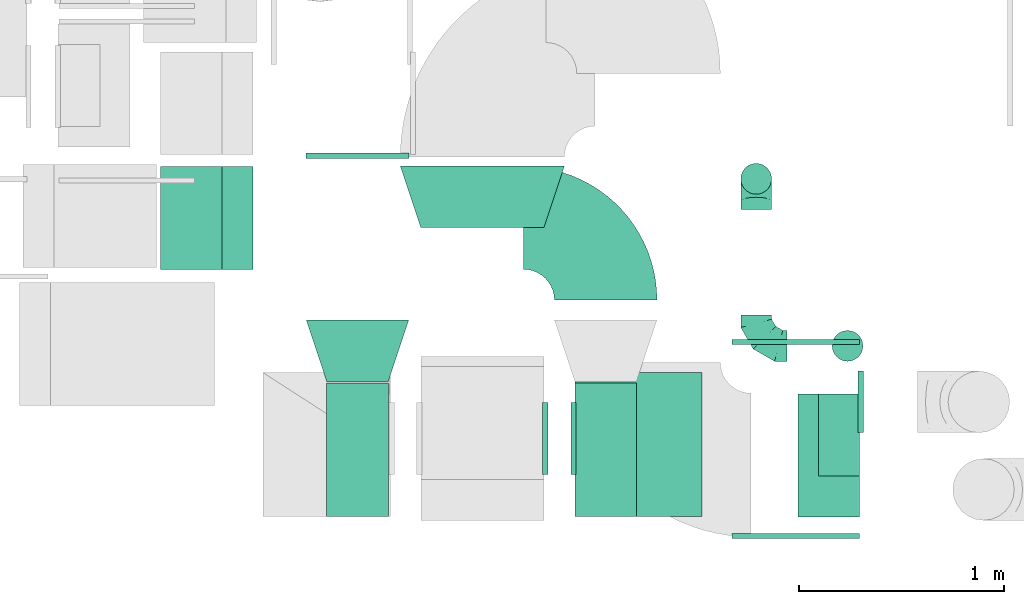
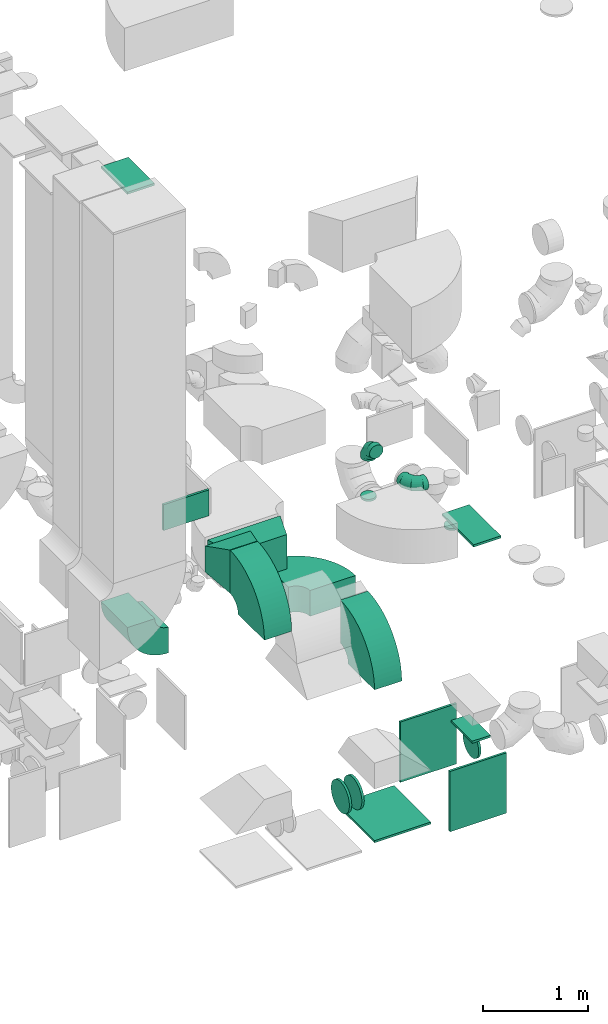
# One storey, part 20 of 59: 20 flow fittings.
"""IFC2X3 building model written with IfcOpenShell, lengths in millimetres."""

from ifc_helpers import new_model, entity, si_unit, converted_unit, derived_unit, direction, frame, frame_2d, origin, origin_2d_with_axis, place, context, subcontext, project, spatial, polyline, circle_curve, parameter, trimmed, segment, composite_curve, rectangle, circle, outline, extrude, faceted_brep, source, transform, mapped, material, type_object, type_shapes, element, save


model = new_model("IFC2X3")

# Units and contexts
model_context = context("Model", 3, precision=0.01, world=origin(), true_north=direction((6.12303176911189e-17, 1.0)))
body_context = subcontext(model_context, "Body", "Model", "MODEL_VIEW")
ifc_project = project(units=[si_unit("LENGTHUNIT", "METRE", prefix="MILLI"), si_unit("AREAUNIT", "SQUARE_METRE"), si_unit("VOLUMEUNIT", "CUBIC_METRE"), converted_unit("PLANEANGLEUNIT", "DEGREE", entity("IfcRatioMeasure", 0.0174532925199433), si_unit("PLANEANGLEUNIT", "RADIAN"), dimensions=[0, 0, 0, 0, 0, 0, 0]), si_unit("MASSUNIT", "GRAM", prefix="KILO"), derived_unit("MASSDENSITYUNIT", [(si_unit("MASSUNIT", "GRAM", prefix="KILO"), 1), (si_unit("LENGTHUNIT", "METRE"), -3)]), derived_unit("MOMENTOFINERTIAUNIT", [(si_unit("LENGTHUNIT", "METRE"), 4)]), si_unit("TIMEUNIT", "SECOND"), si_unit("FREQUENCYUNIT", "HERTZ"), si_unit("THERMODYNAMICTEMPERATUREUNIT", "DEGREE_CELSIUS"), derived_unit("THERMALTRANSMITTANCEUNIT", [(si_unit("MASSUNIT", "GRAM", prefix="KILO"), 1), (si_unit("THERMODYNAMICTEMPERATUREUNIT", "KELVIN"), -1), (si_unit("TIMEUNIT", "SECOND"), -3)]), derived_unit("VOLUMETRICFLOWRATEUNIT", [(si_unit("LENGTHUNIT", "METRE"), 3), (si_unit("TIMEUNIT", "SECOND"), -1)]), derived_unit("MASSFLOWRATEUNIT", [(si_unit("MASSUNIT", "GRAM", prefix="KILO"), 1), (si_unit("TIMEUNIT", "SECOND"), -1)]), derived_unit("ROTATIONALFREQUENCYUNIT", [(si_unit("TIMEUNIT", "SECOND"), -1)]), si_unit("ELECTRICCURRENTUNIT", "AMPERE"), si_unit("ELECTRICVOLTAGEUNIT", "VOLT"), si_unit("POWERUNIT", "WATT"), si_unit("FORCEUNIT", "NEWTON", prefix="KILO"), si_unit("ILLUMINANCEUNIT", "LUX"), si_unit("LUMINOUSFLUXUNIT", "LUMEN"), si_unit("LUMINOUSINTENSITYUNIT", "CANDELA"), derived_unit("USERDEFINED", [(si_unit("MASSUNIT", "GRAM", prefix="KILO"), -1), (si_unit("LENGTHUNIT", "METRE"), -2), (si_unit("TIMEUNIT", "SECOND"), 3), (si_unit("LUMINOUSFLUXUNIT", "LUMEN"), 1)]), derived_unit("LINEARVELOCITYUNIT", [(si_unit("LENGTHUNIT", "METRE"), 1), (si_unit("TIMEUNIT", "SECOND"), -1)]), si_unit("PRESSUREUNIT", "PASCAL"), derived_unit("USERDEFINED", [(si_unit("LENGTHUNIT", "METRE"), -2), (si_unit("MASSUNIT", "GRAM", prefix="KILO"), 1), (si_unit("TIMEUNIT", "SECOND"), -2)]), derived_unit("LINEARFORCEUNIT", [(si_unit("MASSUNIT", "GRAM", prefix="KILO"), 1), (si_unit("LENGTHUNIT", "METRE"), 1), (si_unit("TIMEUNIT", "SECOND"), -2), (si_unit("LENGTHUNIT", "METRE"), -1)]), derived_unit("PLANARFORCEUNIT", [(si_unit("MASSUNIT", "GRAM", prefix="KILO"), 1), (si_unit("LENGTHUNIT", "METRE"), 1), (si_unit("TIMEUNIT", "SECOND"), -2), (si_unit("LENGTHUNIT", "METRE"), -2)])], contexts=[model_context])

# Site, building, storey
site_placement = place(None, origin())
site = spatial("IfcSite", under=ifc_project, at=site_placement, CompositionType="ELEMENT")
building_placement = place(site_placement, origin())
building = spatial("IfcBuilding", under=site, at=building_placement, CompositionType="ELEMENT")
storey_placement = place(building_placement, frame((0.0, 0.0, 28200.0)))
storey = spatial("IfcBuildingStorey", under=building, at=storey_placement, CompositionType="ELEMENT", Elevation=28200.0)

# Flow fittings
ifc_material = material()
duct_fitting_type_1 = type_object("IfcDuctFittingType", PredefinedType="NOTDEFINED", material=ifc_material)
shared_shape_1 = source(origin(), body_context, "Body", "SweptSolid", [
    extrude(rectangle(XDim=26.0960000000224, YDim=500.0, at=origin_2d_with_axis()), frame((6.95, 0.0, -150.0)), (0.0, 0.0, 1.0), 300.0),
])
type_shapes(duct_fitting_type_1, [shared_shape_1])
flow_fitting_1_placement = place(storey_placement, frame((49765.11, 9773.84, 3450.0), z_axis=(0.0, 0.0, -1.0), x_axis=(0.0, -1.0, 0.0)))
element("IfcFlowFitting", 1, at=flow_fitting_1_placement, inside=storey, type_object=duct_fitting_type_1, material=ifc_material, context=body_context, shape_type="MappedRepresentation", body=[
    mapped(shared_shape_1, transform((0.0, 0.0, 0.0), scale=1.0)),
])
duct_fitting_type_2 = type_object("IfcDuctFittingType", PredefinedType="NOTDEFINED", material=ifc_material)
shared_shape_2 = source(origin(), body_context, "Body", "SweptSolid", [
    extrude(rectangle(XDim=24.9999999999999, YDim=500.0, at=origin_2d_with_axis()), frame((12.5, 0.0, -150.0)), (0.0, 0.0, 1.0), 300.0),
])
type_shapes(duct_fitting_type_2, [shared_shape_2])
flow_fitting_2_placement = place(storey_placement, frame((48955.39, 9463.84, 7780.0), z_axis=(1.0, 0.0, 0.0), x_axis=(0.0, 0.0, 1.0)))
element("IfcFlowFitting", 2, at=flow_fitting_2_placement, inside=storey, type_object=duct_fitting_type_2, material=ifc_material, context=body_context, shape_type="MappedRepresentation", body=[
    mapped(shared_shape_2, transform((0.0, 0.0, 0.0), scale=1.0)),
])
duct_fitting_type_3 = type_object("IfcDuctFittingType", PredefinedType="NOTDEFINED", material=ifc_material)
shared_shape_3 = source(origin(), body_context, "Body", "SweptSolid", [
    extrude(rectangle(XDim=24.9999999999999, YDim=620.0, at=origin_2d_with_axis()), frame((12.5, 0.0, -350.0)), (0.0, 0.0, 1.0), 700.0),
])
type_shapes(duct_fitting_type_3, [shared_shape_3])
for number, where, z_axis, x_axis in (
    (3, (51134.61, 8360.0, 300.0), (0.0, 1.0, 0.0), (0.0, 0.0, -1.0)),
    (4, (51900.61, 7927.0, 550.0), (0.0, 0.0, 1.0), (0.0, -1.0, 0.0)),
    (5, (51900.61, 8847.0, 550.0), (0.0, 0.0, 1.0), (0.0, 1.0, 0.0)),
):
    element("IfcFlowFitting", number, at=place(storey_placement, frame(where, z_axis=z_axis, x_axis=x_axis)), inside=storey, type_object=duct_fitting_type_3, material=ifc_material, context=body_context, shape_type="MappedRepresentation", body=[
        mapped(shared_shape_3, transform((0.0, 0.0, 0.0), scale=1.0)),
    ])
duct_fitting_type_4 = type_object("IfcDuctFittingType", PredefinedType="NOTDEFINED", material=ifc_material)
shared_shape_4 = source(origin(), body_context, "Body", "SweptSolid", [
    extrude(rectangle(XDim=26.0960000000046, YDim=200.0, at=origin_2d_with_axis()), frame((6.95, 0.0, -200.0)), (0.0, 0.0, 1.0), 400.0),
])
type_shapes(duct_fitting_type_4, [shared_shape_4])
flow_fitting_3_placement = place(storey_placement, frame((52110.61, 8406.69, 900.0), z_axis=(0.0, -1.0, 0.0), x_axis=(0.0, 0.0, 1.0)))
element("IfcFlowFitting", 6, at=flow_fitting_3_placement, inside=storey, type_object=duct_fitting_type_4, material=ifc_material, context=body_context, shape_type="MappedRepresentation", body=[
    mapped(shared_shape_4, transform((0.0, 0.0, 0.0), scale=1.0)),
])
duct_fitting_type_5 = type_object("IfcDuctFittingType", PredefinedType="NOTDEFINED", material=ifc_material)
shared_shape_5 = source(origin(), body_context, "Body", "SweptSolid", [
    extrude(rectangle(XDim=26.0960000000048, YDim=300.0, at=origin_2d_with_axis()), frame((6.95, 0.0, -300.0)), (0.0, 0.0, 1.0), 600.0),
])
type_shapes(duct_fitting_type_5, [shared_shape_5])
flow_fitting_4_placement = place(storey_placement, frame((52060.61, 8306.69, 3350.0), z_axis=(0.0, 1.0, 0.0), x_axis=(0.0, 0.0, -1.0)))
element("IfcFlowFitting", 7, at=flow_fitting_4_placement, inside=storey, type_object=duct_fitting_type_5, material=ifc_material, context=body_context, shape_type="MappedRepresentation", body=[
    mapped(shared_shape_5, transform((0.0, 0.0, 0.0), scale=1.0)),
])
duct_fitting_type_6 = type_object("IfcDuctFittingType", PredefinedType="NOTDEFINED", material=ifc_material)
shared_shape_6 = source(origin(), body_context, "Body", "SweptSolid", [
    extrude(circle(Radius=74.9999999999995, at=origin_2d_with_axis()), frame((0.0, 0.0, 0.0), z_axis=(1.0, 0.0, 0.0), x_axis=(0.0, 1.0, 0.0)), (0.0, 0.0, 1.0), 25.0000000000018),
])
type_shapes(duct_fitting_type_6, [shared_shape_6])
for number, where, z_axis, x_axis in (
    (8, (51708.0, 9654.72, 3008.0), (0.0, -1.0, 0.0), (0.0, 0.0, -1.0)),
    (9, (52153.19, 8840.5, 3008.0), (0.0, -1.0, 0.0), (0.0, 0.0, -1.0)),
):
    element("IfcFlowFitting", number, at=place(storey_placement, frame(where, z_axis=z_axis, x_axis=x_axis)), inside=storey, type_object=duct_fitting_type_6, material=ifc_material, context=body_context, shape_type="MappedRepresentation", body=[
        mapped(shared_shape_6, transform((0.0, 0.0, 0.0), scale=1.0)),
    ])
duct_fitting_type_7 = type_object("IfcDuctFittingType", PredefinedType="NOTDEFINED", material=ifc_material)
shared_shape_7 = source(origin(), body_context, "Body", "SweptSolid", [
    extrude(outline(polyline([(-268.79, -332.04), (47.43, -332.04), (237.17, 237.17), (-15.81, 426.91), (-268.79, -332.04)])), frame((150.0, 0.0, -200.01), z_axis=(5.7818159732618e-05, 0.0, 1.0), x_axis=(0.948683296623388, 0.316227765541128, -5.48511224715197e-05)), (-5.48511224715197e-05, 1.82837074599458e-05, 1.0), 400.0),
])
type_shapes(duct_fitting_type_7, [shared_shape_7])
flow_fitting_5_placement = place(storey_placement, frame((50373.61, 9717.0, 2855.0), z_axis=(0.0, -4.00643741305655e-05, 1.0), x_axis=(1.85007582336496e-08, -1.0, -4.00643741305654e-05)))
element("IfcFlowFitting", 10, at=flow_fitting_5_placement, inside=storey, type_object=duct_fitting_type_7, material=ifc_material, context=body_context, shape_type="MappedRepresentation", body=[
    mapped(shared_shape_7, transform((0.0, 0.0, 0.0), scale=1.0)),
])
duct_fitting_type_8 = type_object("IfcDuctFittingType", PredefinedType="NOTDEFINED", material=ifc_material)
shared_shape_8 = source(origin(), body_context, "Body", "Brep", [
    faceted_brep([(300.0, -250.0, 150.0), (300.0, -250.0, -150.0), (300.0, 250.0, -150.0), (300.0, 250.0, 150.0), (0.0, -150.0, 250.0), (0.0, 150.0, 250.0), (0.0, 150.0, -250.0), (0.0, -150.0, -250.0)], [[[0, 1, 2, 3]], [[4, 5, 6, 7]], [[4, 7, 1, 0]], [[7, 6, 2, 1]], [[6, 5, 3, 2]], [[5, 4, 0, 3]]]),
])
type_shapes(duct_fitting_type_8, [shared_shape_8])
flow_fitting_6_placement = place(storey_placement, frame((49765.11, 8666.84, 3450.0), z_axis=(0.0, 0.0, 1.0), x_axis=(0.0, 1.0, 0.0)))
element("IfcFlowFitting", 11, at=flow_fitting_6_placement, inside=storey, type_object=duct_fitting_type_8, material=ifc_material, context=body_context, shape_type="MappedRepresentation", body=[
    mapped(shared_shape_8, transform((0.0, 0.0, 0.0), scale=1.0)),
])
duct_fitting_type_9 = type_object("IfcDuctFittingType", PredefinedType="NOTDEFINED", material=ifc_material)
shared_shape_9 = source(origin(), body_context, "Body", "Brep", [
    faceted_brep([(20.0, 38.82, -144.89), (20.0, 75.0, -129.9), (20.0, 106.07, -106.07), (20.0, 129.9, -75.0), (20.0, 144.89, -38.82), (20.0, 150.0, 0.0), (20.0, 144.89, 38.82), (20.0, 129.9, 75.0), (20.0, 106.07, 106.07), (20.0, 75.0, 129.9), (20.0, 38.82, 144.89), (20.0, 0.0, 150.0), (20.0, -38.82, 144.89), (20.0, -75.0, 129.9), (20.0, -106.07, 106.07), (20.0, -129.9, 75.0), (20.0, -144.89, 38.82), (20.0, -150.0, 0.0), (20.0, -144.89, -38.82), (20.0, -129.9, -75.0), (20.0, -106.07, -106.07), (20.0, -75.0, -129.9), (20.0, -38.82, -144.89), (20.0, 0.0, -150.0), (0.0, 0.0, 150.0), (0.0, 38.82, 144.89), (-6.1, 38.82, 144.89), (-6.1, 0.0, 150.0), (0.0, 75.0, 129.9), (-6.1, 75.0, 129.9), (0.0, 106.07, 106.07), (-6.1, 106.07, 106.07), (0.0, 129.9, 75.0), (0.0, 144.89, 38.82), (-6.1, 144.89, 38.82), (-6.1, 129.9, 75.0), (0.0, 150.0, 0.0), (-6.1, 150.0, 0.0), (0.0, 144.89, -38.82), (-6.1, 144.89, -38.82), (0.0, 129.9, -75.0), (-6.1, 129.9, -75.0), (0.0, 106.07, -106.07), (-6.1, 106.07, -106.07), (0.0, 75.0, -129.9), (0.0, 38.82, -144.89), (-6.1, 38.82, -144.89), (-6.1, 75.0, -129.9), (0.0, 0.0, -150.0), (-6.1, 0.0, -150.0), (0.0, -38.82, -144.89), (-6.1, -38.82, -144.89), (0.0, -75.0, -129.9), (-6.1, -75.0, -129.9), (0.0, -106.07, -106.07), (-6.1, -106.07, -106.07), (0.0, -129.9, -75.0), (0.0, -144.89, -38.82), (-6.1, -144.89, -38.82), (-6.1, -129.9, -75.0), (0.0, -150.0, 0.0), (-6.1, -150.0, 0.0), (0.0, -144.89, 38.82), (-6.1, -144.89, 38.82), (0.0, -129.9, 75.0), (-6.1, -129.9, 75.0), (0.0, -106.07, 106.07), (-6.1, -106.07, 106.07), (0.0, -75.0, 129.9), (0.0, -38.82, 144.89), (-6.1, -38.82, 144.89), (-6.1, -75.0, 129.9)], [[[0, 1, 2, 3, 4, 5, 6, 7, 8, 9, 10, 11, 12, 13, 14, 15, 16, 17, 18, 19, 20, 21, 22, 23]], [[24, 11, 10, 25, 26, 27]], [[25, 10, 9, 28, 29, 26]], [[28, 9, 8, 30, 31, 29]], [[32, 7, 6, 33, 34, 35]], [[33, 6, 5, 36, 37, 34]], [[30, 8, 7, 32, 35, 31]], [[36, 5, 4, 38, 39, 37]], [[38, 4, 3, 40, 41, 39]], [[40, 3, 2, 42, 43, 41]], [[44, 1, 0, 45, 46, 47]], [[45, 0, 23, 48, 49, 46]], [[42, 2, 1, 44, 47, 43]], [[48, 23, 22, 50, 51, 49]], [[50, 22, 21, 52, 53, 51]], [[52, 21, 20, 54, 55, 53]], [[56, 19, 18, 57, 58, 59]], [[57, 18, 17, 60, 61, 58]], [[54, 20, 19, 56, 59, 55]], [[60, 17, 16, 62, 63, 61]], [[62, 16, 15, 64, 65, 63]], [[64, 15, 14, 66, 67, 65]], [[68, 13, 12, 69, 70, 71]], [[69, 12, 11, 24, 27, 70]], [[66, 14, 13, 68, 71, 67]], [[49, 51, 53, 55, 59, 58, 61, 63, 65, 67, 71, 70, 27, 26, 29, 31, 35, 34, 37, 39, 41, 43, 47, 46]]]),
])
type_shapes(duct_fitting_type_9, [shared_shape_9])
flow_fitting_7_placement = place(storey_placement, frame((52210.61, 8567.36, 605.29), z_axis=(0.0, 0.0, -1.0), x_axis=(1.0, 0.0, 0.0)))
element("IfcFlowFitting", 12, at=flow_fitting_7_placement, inside=storey, type_object=duct_fitting_type_9, material=ifc_material, context=body_context, shape_type="MappedRepresentation", body=[
    mapped(shared_shape_9, transform((0.0, 0.0, 0.0), scale=1.0)),
])
duct_fitting_type_10 = type_object("IfcDuctFittingType", PredefinedType="NOTDEFINED", material=ifc_material)
shared_shape_10 = source(origin(), body_context, "Body", "Brep", [
    faceted_brep([(20.0, 0.0, -175.0), (20.0, 45.29, -169.04), (20.0, 87.5, -151.55), (20.0, 123.74, -123.74), (20.0, 151.55, -87.5), (20.0, 169.04, -45.29), (20.0, 175.0, 0.0), (20.0, 169.04, 45.29), (20.0, 151.55, 87.5), (20.0, 123.74, 123.74), (20.0, 87.5, 151.55), (20.0, 45.29, 169.04), (20.0, 0.0, 175.0), (20.0, -45.29, 169.04), (20.0, -87.5, 151.55), (20.0, -123.74, 123.74), (20.0, -151.55, 87.5), (20.0, -169.04, 45.29), (20.0, -175.0, 0.0), (20.0, -169.04, -45.29), (20.0, -151.55, -87.5), (20.0, -123.74, -123.74), (20.0, -87.5, -151.55), (20.0, -45.29, -169.04), (0.0, 0.0, 175.0), (0.0, -28.54, 171.24), (0.0, -45.29, 169.04), (-6.1, -22.65, 172.02), (-6.1, 0.0, 175.0), (-6.1, -45.29, 169.04), (0.0, -66.4, 160.3), (0.0, -87.5, 151.55), (-6.1, -66.4, 160.3), (-6.1, -87.5, 151.55), (0.0, -105.62, 137.65), (0.0, -123.74, 123.74), (-6.1, -105.62, 137.65), (-6.1, -123.74, 123.74), (0.0, -151.55, 87.5), (0.0, -160.3, 66.4), (0.0, -169.04, 45.29), (-6.1, -151.55, 87.5), (-6.1, -160.3, 66.4), (-6.1, -169.04, 45.29), (0.0, -172.02, 22.65), (0.0, -175.0, 0.0), (-6.1, -171.24, 28.54), (-6.1, -175.0, 0.0), (0.0, -137.65, 105.62), (-6.1, -137.65, 105.62), (0.0, -171.24, -28.54), (0.0, -169.04, -45.29), (-6.1, -172.02, -22.65), (-6.1, -169.04, -45.29), (0.0, -160.3, -66.4), (0.0, -151.55, -87.5), (-6.1, -160.3, -66.4), (-6.1, -151.55, -87.5), (0.0, -137.65, -105.62), (0.0, -123.74, -123.74), (-6.1, -137.65, -105.62), (-6.1, -123.74, -123.74), (0.0, -87.5, -151.55), (0.0, -66.4, -160.3), (0.0, -45.29, -169.04), (-6.1, -66.4, -160.3), (-6.1, -87.5, -151.55), (-6.1, -45.29, -169.04), (0.0, 0.0, -175.0), (0.0, -28.54, -171.24), (-6.1, -22.65, -172.02), (-6.1, 0.0, -175.0), (0.0, -105.62, -137.65), (-6.1, -105.62, -137.65), (0.0, 28.54, -171.24), (0.0, 45.29, -169.04), (-6.1, 22.65, -172.02), (-6.1, 45.29, -169.04), (0.0, 66.4, -160.3), (0.0, 87.5, -151.55), (-6.1, 66.4, -160.3), (-6.1, 87.5, -151.55), (0.0, 105.62, -137.65), (0.0, 123.74, -123.74), (-6.1, 105.62, -137.65), (-6.1, 123.74, -123.74), (0.0, 175.0, 0.0), (0.0, 171.24, -28.54), (-6.1, 172.02, -22.65), (-6.1, 175.0, 0.0), (0.0, 169.04, -45.29), (-6.1, 169.04, -45.29), (0.0, 151.55, -87.5), (0.0, 160.3, -66.4), (-6.1, 151.55, -87.5), (-6.1, 160.3, -66.4), (0.0, 137.65, -105.62), (-6.1, 137.65, -105.62), (0.0, 171.24, 28.54), (0.0, 169.04, 45.29), (-6.1, 172.02, 22.65), (-6.1, 169.04, 45.29), (0.0, 160.3, 66.4), (0.0, 151.55, 87.5), (-6.1, 160.3, 66.4), (-6.1, 151.55, 87.5), (0.0, 137.65, 105.62), (0.0, 123.74, 123.74), (-6.1, 137.65, 105.62), (-6.1, 123.74, 123.74), (0.0, 87.5, 151.55), (0.0, 66.4, 160.3), (0.0, 45.29, 169.04), (-6.1, 87.5, 151.55), (-6.1, 66.4, 160.3), (-6.1, 45.29, 169.04), (0.0, 22.65, 172.02), (-6.1, 28.54, 171.24), (0.0, 105.62, 137.65), (-6.1, 105.62, 137.65)], [[[0, 1, 2, 3, 4, 5, 6, 7, 8, 9, 10, 11, 12, 13, 14, 15, 16, 17, 18, 19, 20, 21, 22, 23]], [[13, 12, 24]], [[13, 24, 25]], [[13, 25, 26]], [[27, 25, 24]], [[27, 24, 28]], [[27, 29, 25]], [[25, 29, 26]], [[14, 13, 26]], [[14, 26, 30]], [[14, 30, 31]], [[26, 29, 30]], [[32, 30, 29]], [[30, 32, 31]], [[32, 33, 31]], [[15, 31, 34]], [[14, 31, 15]], [[15, 34, 35]], [[34, 31, 33]], [[34, 33, 36]], [[36, 37, 35]], [[34, 36, 35]], [[17, 16, 38]], [[17, 38, 39]], [[17, 39, 40]], [[38, 41, 39]], [[42, 39, 41]], [[39, 42, 40]], [[42, 43, 40]], [[18, 17, 40]], [[18, 40, 44]], [[18, 44, 45]], [[44, 40, 46]], [[43, 46, 40]], [[44, 46, 47]], [[45, 44, 47]], [[16, 35, 48]], [[15, 35, 16]], [[16, 48, 38]], [[48, 35, 37]], [[48, 37, 49]], [[48, 49, 38]], [[49, 41, 38]], [[19, 18, 45]], [[19, 45, 50]], [[19, 50, 51]], [[52, 50, 45]], [[52, 45, 47]], [[52, 53, 50]], [[50, 53, 51]], [[20, 19, 51]], [[20, 51, 54]], [[20, 54, 55]], [[51, 53, 54]], [[56, 54, 53]], [[54, 56, 55]], [[56, 57, 55]], [[21, 55, 58]], [[20, 55, 21]], [[21, 58, 59]], [[58, 55, 57]], [[58, 57, 60]], [[60, 61, 59]], [[58, 60, 59]], [[23, 22, 62]], [[23, 62, 63]], [[23, 63, 64]], [[63, 62, 65]], [[66, 65, 62]], [[65, 67, 63]], [[67, 64, 63]], [[0, 23, 68]], [[23, 69, 68]], [[23, 64, 69]], [[64, 67, 69]], [[70, 69, 67]], [[70, 71, 68]], [[69, 70, 68]], [[21, 59, 72]], [[21, 72, 62]], [[22, 21, 62]], [[72, 59, 73]], [[59, 61, 73]], [[73, 66, 72]], [[62, 72, 66]], [[1, 0, 68]], [[1, 68, 74]], [[1, 74, 75]], [[76, 74, 68]], [[76, 68, 71]], [[76, 77, 74]], [[74, 77, 75]], [[2, 1, 75]], [[2, 75, 78]], [[2, 78, 79]], [[75, 77, 78]], [[80, 78, 77]], [[78, 80, 79]], [[80, 81, 79]], [[3, 79, 82]], [[2, 79, 3]], [[3, 82, 83]], [[82, 79, 81]], [[82, 81, 84]], [[84, 85, 83]], [[82, 84, 83]], [[86, 6, 5]], [[5, 87, 86]], [[87, 88, 86]], [[88, 89, 86]], [[5, 90, 87]], [[90, 91, 87]], [[88, 87, 91]], [[92, 5, 4]], [[5, 92, 93]], [[92, 94, 93]], [[95, 93, 94]], [[90, 93, 95]], [[95, 91, 90]], [[5, 93, 90]], [[4, 83, 96]], [[3, 83, 4]], [[4, 96, 92]], [[96, 83, 85]], [[96, 85, 97]], [[96, 97, 92]], [[97, 94, 92]], [[7, 6, 86]], [[7, 86, 98]], [[7, 98, 99]], [[100, 98, 86]], [[100, 86, 89]], [[100, 101, 98]], [[98, 101, 99]], [[8, 7, 99]], [[8, 99, 102]], [[8, 102, 103]], [[99, 101, 102]], [[104, 102, 101]], [[102, 104, 103]], [[104, 105, 103]], [[9, 103, 106]], [[8, 103, 9]], [[9, 106, 107]], [[106, 103, 105]], [[106, 105, 108]], [[108, 109, 107]], [[106, 108, 107]], [[11, 10, 110]], [[11, 110, 111]], [[11, 111, 112]], [[110, 113, 111]], [[114, 111, 113]], [[111, 114, 112]], [[114, 115, 112]], [[12, 11, 112]], [[12, 112, 116]], [[12, 116, 24]], [[116, 112, 117]], [[115, 117, 112]], [[116, 117, 28]], [[24, 116, 28]], [[10, 107, 118]], [[9, 107, 10]], [[10, 118, 110]], [[118, 107, 109]], [[118, 109, 119]], [[118, 119, 110]], [[119, 113, 110]], [[43, 42, 41, 49, 37, 36, 33, 32, 29, 27, 28, 117, 115, 114, 113, 119, 109, 108, 105, 104, 101, 100, 89, 88, 91, 95, 94, 97, 85, 84, 81, 80, 77, 76, 71, 70, 67, 65, 66, 73, 61, 60, 57, 56, 53, 52, 47, 46]]]),
])
type_shapes(duct_fitting_type_10, [shared_shape_10])
for number, where, z_axis, x_axis in (
    (13, (50673.61, 8389.55, 637.52), (0.0, -1.0, 0.0), (1.0, 0.0, 0.0)),
    (14, (50824.61, 8389.55, 637.52), (0.0, 1.0, 0.0), (-1.0, 0.0, 0.0)),
):
    element("IfcFlowFitting", number, at=place(storey_placement, frame(where, z_axis=z_axis, x_axis=x_axis)), inside=storey, type_object=duct_fitting_type_10, material=ifc_material, context=body_context, shape_type="MappedRepresentation", body=[
        mapped(shared_shape_10, transform((0.0, 0.0, 0.0), scale=1.0)),
    ])
duct_fitting_type_11 = type_object("IfcDuctFittingType", PredefinedType="NOTDEFINED", material=ifc_material)
shared_shape_11 = source(origin(), body_context, "Body", "Brep", [
    faceted_brep([(-150.0, 0.0, -75.0), (-150.0, -19.41, -72.44), (-150.0, -37.5, -64.95), (-150.0, -53.03, -53.03), (-150.0, -64.95, -37.5), (-150.0, -72.44, -19.41), (-150.0, -75.0, 0.0), (-150.0, -72.44, 19.41), (-150.0, -64.95, 37.5), (-150.0, -53.03, 53.03), (-150.0, -37.5, 64.95), (-150.0, -19.41, 72.44), (-150.0, 0.0, 75.0), (-150.0, 19.41, 72.44), (-150.0, 37.5, 64.95), (-150.0, 53.03, 53.03), (-150.0, 64.95, 37.5), (-150.0, 72.44, 19.41), (-150.0, 75.0, 0.0), (-150.0, 72.44, -19.41), (-150.0, 64.95, -37.5), (-150.0, 53.03, -53.03), (-150.0, 37.5, -64.95), (-150.0, 19.41, -72.44), (-115.01, 19.41, 72.44), (-119.86, 37.5, 64.95), (-109.81, 0.0, 75.0), (-124.02, 53.03, 53.03), (-129.22, 72.44, 19.41), (-129.9, 75.0, 0.0), (-127.21, 64.95, 37.5), (-127.21, 64.95, -37.5), (-124.02, 53.03, -53.03), (-129.22, 72.44, -19.41), (-115.01, 19.41, -72.44), (-109.81, 0.0, -75.0), (-119.86, 37.5, -64.95), (-104.61, -19.41, -72.44), (-99.76, -37.5, -64.95), (-95.6, -53.03, -53.03), (-92.4, -64.95, -37.5), (-90.4, -72.44, -19.41), (-89.71, -75.0, 0.0), (-90.4, -72.44, 19.41), (-92.4, -64.95, 37.5), (-95.6, -53.03, 53.03), (-99.76, -37.5, 64.95), (-104.61, -19.41, 72.44), (-54.4, 54.4, 72.44), (-67.64, 67.64, 64.95), (-40.19, 40.19, 75.0), (-79.02, 79.02, 53.03), (-87.74, 87.74, 37.5), (-93.23, 93.23, 19.41), (-95.1, 95.1, 0.0), (-93.23, 93.23, -19.41), (-87.74, 87.74, -37.5), (-79.02, 79.02, -53.03), (-54.4, 54.4, -72.44), (-40.19, 40.19, -75.0), (-67.64, 67.64, -64.95), (-25.98, 25.98, -72.44), (-12.74, 12.74, -64.95), (-1.37, 1.37, -53.03), (7.36, -7.36, -37.5), (12.84, -12.84, -19.41), (14.71, -14.71, 0.0), (12.84, -12.84, 19.41), (7.36, -7.36, 37.5), (-1.37, 1.37, 53.03), (-12.74, 12.74, 64.95), (-25.98, 25.98, 72.44), (-19.41, 115.01, 72.44), (-37.5, 119.86, 64.95), (0.0, 109.81, 75.0), (-53.03, 124.02, 53.03), (-64.95, 127.21, 37.5), (-72.44, 129.22, 19.41), (-75.0, 129.9, 0.0), (-72.44, 129.22, -19.41), (-64.95, 127.21, -37.5), (-53.03, 124.02, -53.03), (-19.41, 115.01, -72.44), (0.0, 109.81, -75.0), (-37.5, 119.86, -64.95), (19.41, 104.61, -72.44), (37.5, 99.76, -64.95), (53.03, 95.6, -53.03), (64.95, 92.4, -37.5), (72.44, 90.4, -19.41), (75.0, 89.71, 0.0), (72.44, 90.4, 19.41), (64.95, 92.4, 37.5), (53.03, 95.6, 53.03), (37.5, 99.76, 64.95), (19.41, 104.61, 72.44), (-19.41, 150.0, -72.44), (-37.5, 150.0, -64.95), (-53.03, 150.0, -53.03), (-64.95, 150.0, -37.5), (-72.44, 150.0, -19.41), (-75.0, 150.0, 0.0), (-72.44, 150.0, 19.41), (-64.95, 150.0, 37.5), (-53.03, 150.0, 53.03), (-37.5, 150.0, 64.95), (-19.41, 150.0, 72.44), (0.0, 150.0, 75.0), (19.41, 150.0, 72.44), (37.5, 150.0, 64.95), (53.03, 150.0, 53.03), (64.95, 150.0, 37.5), (72.44, 150.0, 19.41), (75.0, 150.0, 0.0), (72.44, 150.0, -19.41), (64.95, 150.0, -37.5), (53.03, 150.0, -53.03), (37.5, 150.0, -64.95), (19.41, 150.0, -72.44), (0.0, 150.0, -75.0)], [[[0, 1, 2, 3, 4, 5, 6, 7, 8, 9, 10, 11, 12, 13, 14, 15, 16, 17, 18, 19, 20, 21, 22, 23]], [[24, 25, 14, 13]], [[26, 24, 13, 12]], [[14, 25, 27, 15]], [[28, 29, 18, 17]], [[30, 28, 17, 16]], [[15, 27, 30, 16]], [[20, 31, 32, 21]], [[33, 31, 20, 19]], [[18, 29, 33, 19]], [[34, 35, 0, 23]], [[36, 34, 23, 22]], [[21, 32, 36, 22]], [[1, 0, 35, 37]], [[2, 1, 37, 38]], [[3, 2, 38, 39]], [[5, 4, 40, 41]], [[6, 5, 41, 42]], [[39, 40, 4, 3]], [[6, 42, 43, 7]], [[7, 43, 44, 8]], [[8, 44, 45, 9]], [[9, 45, 46, 10]], [[10, 46, 47, 11]], [[26, 12, 11, 47]], [[48, 49, 25, 24]], [[50, 48, 24, 26]], [[27, 25, 49, 51]], [[52, 53, 28, 30]], [[51, 52, 30, 27]], [[29, 28, 53, 54]], [[55, 56, 31, 33]], [[54, 55, 33, 29]], [[32, 31, 56, 57]], [[58, 59, 35, 34]], [[60, 58, 34, 36]], [[57, 60, 36, 32]], [[37, 35, 59, 61]], [[38, 37, 61, 62]], [[39, 38, 62, 63]], [[41, 40, 64, 65]], [[42, 41, 65, 66]], [[63, 64, 40, 39]], [[43, 42, 66, 67]], [[44, 43, 67, 68]], [[68, 69, 45, 44]], [[46, 45, 69, 70]], [[47, 46, 70, 71]], [[26, 47, 71, 50]], [[72, 73, 49, 48]], [[74, 72, 48, 50]], [[51, 49, 73, 75]], [[76, 77, 53, 52]], [[75, 76, 52, 51]], [[54, 53, 77, 78]], [[79, 80, 56, 55]], [[78, 79, 55, 54]], [[57, 56, 80, 81]], [[82, 83, 59, 58]], [[84, 82, 58, 60]], [[81, 84, 60, 57]], [[61, 59, 83, 85]], [[62, 61, 85, 86]], [[63, 62, 86, 87]], [[65, 64, 88, 89]], [[66, 65, 89, 90]], [[87, 88, 64, 63]], [[67, 66, 90, 91]], [[68, 67, 91, 92]], [[92, 93, 69, 68]], [[70, 69, 93, 94]], [[71, 70, 94, 95]], [[50, 71, 95, 74]], [[96, 97, 98, 99, 100, 101, 102, 103, 104, 105, 106, 107, 108, 109, 110, 111, 112, 113, 114, 115, 116, 117, 118, 119]], [[72, 74, 107, 106]], [[73, 72, 106, 105]], [[75, 73, 105, 104]], [[77, 76, 103, 102]], [[78, 77, 102, 101]], [[75, 104, 103, 76]], [[78, 101, 100, 79]], [[79, 100, 99, 80]], [[80, 99, 98, 81]], [[84, 97, 96, 82]], [[82, 96, 119, 83]], [[84, 81, 98, 97]], [[83, 119, 118, 85]], [[85, 118, 117, 86]], [[116, 87, 86, 117]], [[88, 115, 114, 89]], [[89, 114, 113, 90]], [[115, 88, 87, 116]], [[112, 111, 92, 91]], [[113, 112, 91, 90]], [[111, 110, 93, 92]], [[95, 94, 109, 108]], [[74, 95, 108, 107]], [[110, 109, 94, 93]]]),
])
type_shapes(duct_fitting_type_11, [shared_shape_11])
for number, where, z_axis, x_axis in (
    (15, (51708.0, 8840.5, 3600.0), (0.0, 0.0, 1.0), (0.0, -1.0, 0.0)),
    (16, (51708.0, 9654.72, 3600.0), (-1.0, 0.0, 0.0), (0.0, 1.0, 0.0)),
):
    element("IfcFlowFitting", number, at=place(storey_placement, frame(where, z_axis=z_axis, x_axis=x_axis)), inside=storey, type_object=duct_fitting_type_11, material=ifc_material, context=body_context, shape_type="MappedRepresentation", body=[
        mapped(shared_shape_11, transform((0.0, 0.0, 0.0), scale=1.0)),
    ])
duct_fitting_type_12 = type_object("IfcDuctFittingType", PredefinedType="NOTDEFINED", material=ifc_material)
shared_shape_12 = source(origin(), body_context, "Body", "SweptSolid", [
    extrude(outline(composite_curve([segment(polyline([(-450.0, -200.0), (50.0, -200.0)]), True, "CONTINUOUS"), segment(trimmed(circle_curve(frame_2d((200.0, -200.0), x_axis=(0.0, 1.0)), 150.0), [parameter(0.0)], [parameter(90.0000000000001)], True, "PARAMETER"), False, "CONTINUOUS"), segment(polyline([(200.0, -50.0), (200.0, 450.0)]), True, "CONTINUOUS"), segment(trimmed(circle_curve(frame_2d((200.0, -200.0), x_axis=(0.0, 1.0)), 650.0), [parameter(0.0)], [parameter(90.0000000000001)], True, "PARAMETER"), True, "CONTINUOUS")], self_intersect=False)), frame((-200.0, 200.0, -150.0), z_axis=(0.0, 0.0, 1.0), x_axis=(-1.0, 0.0, 0.0)), (0.0, 0.0, 1.0), 300.0),
])
type_shapes(duct_fitting_type_12, [shared_shape_12])
for number, where, z_axis, x_axis in (
    (17, (50974.61, 8260.0, 2450.0), (1.0, 0.0, 0.0), (0.0, -1.0, 0.0)),
    (18, (50974.61, 9463.84, 2450.0), (0.0, 0.0, 1.0), (0.0, 1.0, 0.0)),
):
    element("IfcFlowFitting", number, at=place(storey_placement, frame(where, z_axis=z_axis, x_axis=x_axis)), inside=storey, type_object=duct_fitting_type_12, material=ifc_material, context=body_context, shape_type="MappedRepresentation", body=[
        mapped(shared_shape_12, transform((0.0, 0.0, 0.0), scale=1.0)),
    ])
duct_fitting_type_13 = type_object("IfcDuctFittingType", PredefinedType="NOTDEFINED", material=ifc_material)
shared_shape_13 = source(origin(), body_context, "Body", "SweptSolid", [
    extrude(outline(composite_curve([segment(polyline([(-300.0, -150.0), (0.0, -150.0)]), True, "CONTINUOUS"), segment(trimmed(circle_curve(frame_2d((150.0, -150.0), x_axis=(0.0, 1.0)), 150.0), [parameter(0.0)], [parameter(90.0)], True, "PARAMETER"), False, "CONTINUOUS"), segment(polyline([(150.0, 0.0), (150.0, 300.0)]), True, "CONTINUOUS"), segment(trimmed(circle_curve(frame_2d((150.0, -150.0), x_axis=(0.0, 1.0)), 450.0), [parameter(0.0)], [parameter(90.0000000000001)], True, "PARAMETER"), True, "CONTINUOUS")], self_intersect=False)), frame((-150.0, 150.0, -250.0), z_axis=(0.0, 0.0, 1.0), x_axis=(-1.0, 0.0, 0.0)), (0.0, 0.0, 1.0), 500.0),
])
type_shapes(duct_fitting_type_13, [shared_shape_13])
flow_fitting_8_placement = place(storey_placement, frame((48955.39, 9463.84, 2450.0), z_axis=(0.0, -1.0, 0.0), x_axis=(0.0, 0.0, -1.0)))
element("IfcFlowFitting", 19, at=flow_fitting_8_placement, inside=storey, type_object=duct_fitting_type_13, material=ifc_material, context=body_context, shape_type="MappedRepresentation", body=[
    mapped(shared_shape_13, transform((0.0, 0.0, 0.0), scale=1.0)),
])
duct_fitting_type_14 = type_object("IfcDuctFittingType", PredefinedType="NOTDEFINED", material=ifc_material)
shared_shape_14 = source(origin(), body_context, "Body", "SweptSolid", [
    extrude(outline(composite_curve([segment(trimmed(circle_curve(frame_2d((-200.0, 200.0), x_axis=(1.0, 0.0)), 650.0), [parameter(270.0)], [parameter(0.0)], True, "PARAMETER"), True, "CONTINUOUS"), segment(polyline([(450.0, 200.0), (-50.0, 200.0)]), True, "CONTINUOUS"), segment(trimmed(circle_curve(frame_2d((-200.0, 200.0), x_axis=(1.0, 0.0)), 150.0), [parameter(270.0)], [parameter(0.0)], True, "PARAMETER"), False, "CONTINUOUS"), segment(polyline([(-200.0, 50.0), (-200.0, -450.0)]), True, "CONTINUOUS")], self_intersect=False)), frame((-200.0, -200.0, -150.0), z_axis=(0.0, 0.0, 1.0), x_axis=(0.0, 1.0, 0.0)), (0.0, 0.0, 1.0), 300.0),
])
type_shapes(duct_fitting_type_14, [shared_shape_14])
flow_fitting_9_placement = place(storey_placement, frame((49765.11, 8260.0, 3450.0), z_axis=(-1.0, 0.0, 0.0), x_axis=(0.0, -1.0, 0.0)))
element("IfcFlowFitting", 20, at=flow_fitting_9_placement, inside=storey, type_object=duct_fitting_type_14, material=ifc_material, context=body_context, shape_type="MappedRepresentation", body=[
    mapped(shared_shape_14, transform((0.0, 0.0, 0.0), scale=1.0)),
])

save(model, "model.ifc")
